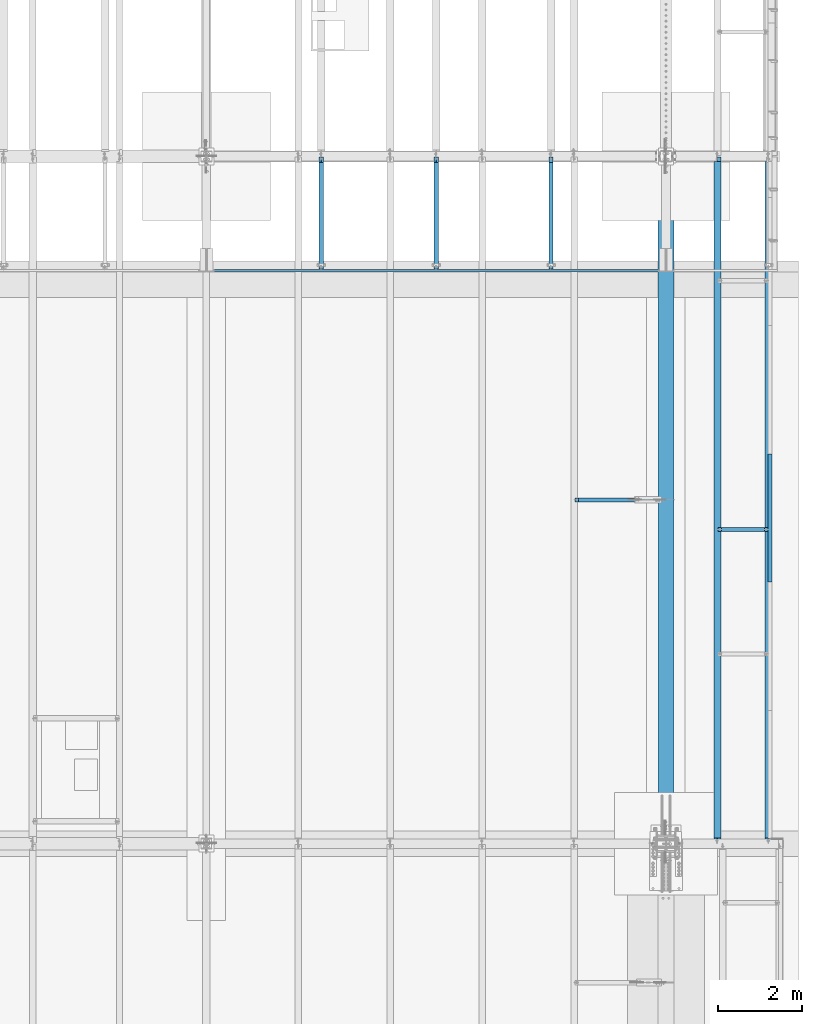
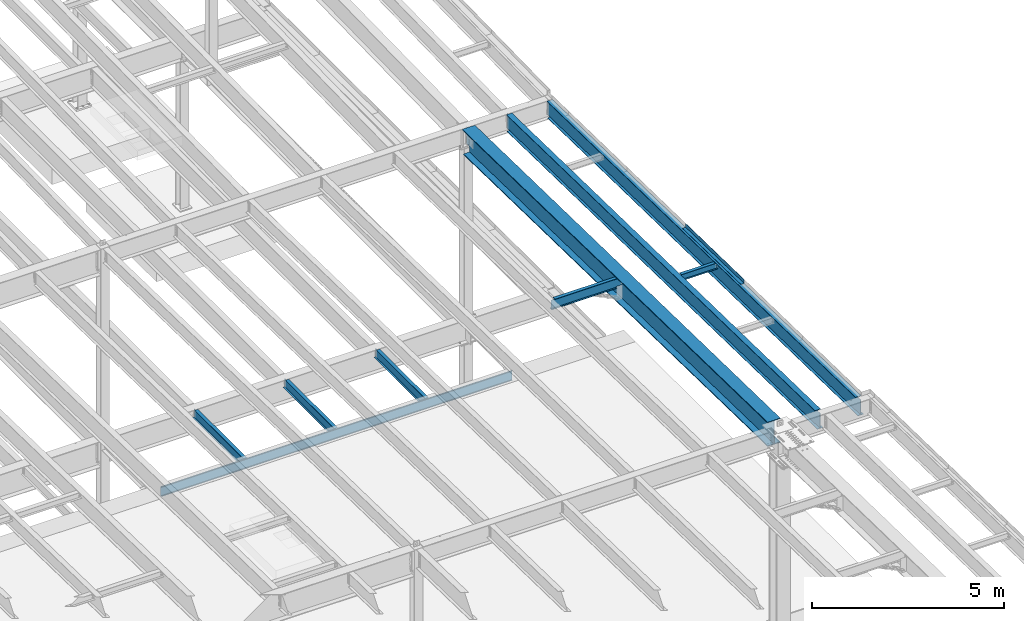
# One storey, part 1118 of 1763: 10 beams, 9 elements without a shape of their own.
"""IFC2X3 building model written with IfcOpenShell, lengths in millimetres."""

import ifcopenshell
import ifcopenshell.guid

model = None  # the IFC model being written
_history = None  # IfcOwnerHistory: only IFC2X3 demands one
_inside = {}  # id of a spatial element -> (the spatial element, [elements in it])
_under = {}  # id of a project, library or spatial element -> (it, [spatial elements below it])
_declared = {}  # id of a project -> (the project, [libraries it declares])
_typed = {}  # id of a type object -> (the type object, [elements of that type])
_made_of = {}  # id of a material, layer set ... -> (it, [elements and type objects made of it])


def new_model(schema):
    """Start an empty IFC model of exactly this schema.

    Asked for "IFC4X3", IfcOpenShell would pick the latest addendum, in which some entities
    have other attributes; the version numbers below select the first issue.
    IFC2X3 requires an IfcOwnerHistory on every rooted entity: one is made here for all.
    """
    global model, _history
    if schema == "IFC4X3":
        model = ifcopenshell.file(schema_version=(4, 3, 0, 0))
    else:
        model = ifcopenshell.file(schema=schema)
    _inside.clear()
    _under.clear()
    _declared.clear()
    _typed.clear()
    _made_of.clear()
    _history = None
    if model.schema == "IFC2X3":
        org = make("IfcOrganization", Name="unknown")
        user = make(
            "IfcPersonAndOrganization",
            ThePerson=make("IfcPerson", FamilyName="unknown"),
            TheOrganization=org,
        )
        app = make(
            "IfcApplication",
            ApplicationDeveloper=org,
            Version="unknown",
            ApplicationFullName="unknown",
            ApplicationIdentifier="unknown",
        )
        _history = make(
            "IfcOwnerHistory",
            OwningUser=user,
            OwningApplication=app,
            ChangeAction="ADDED",
            CreationDate=0,
        )
    return model


def make(cls, **values):
    """One entity of the class cls with the attributes given. An attribute that is None is left unset."""
    return model.create_entity(
        cls, **{name: value for name, value in values.items() if value is not None}
    )


def rooted(cls, **values):
    """An entity with a GlobalId (a new one), such as an element, a storey or a relation."""
    return make(cls, GlobalId=ifcopenshell.guid.new(), OwnerHistory=_history, **values)


def si_unit(unit_type, name, prefix=None):
    """IfcSIUnit, for example si_unit("LENGTHUNIT", "METRE", prefix="MILLI")."""
    return make("IfcSIUnit", UnitType=unit_type, Prefix=prefix, Name=name)


def assignment(units):
    """IfcUnitAssignment: the units of a project."""
    return None if units is None else make("IfcUnitAssignment", Units=units)


def point(xyz):
    """IfcCartesianPoint."""
    return None if xyz is None else make("IfcCartesianPoint", Coordinates=xyz)


def direction(xyz):
    """IfcDirection."""
    return None if xyz is None else make("IfcDirection", DirectionRatios=xyz)


def frame(location, z_axis=None, x_axis=None):
    """IfcAxis2Placement3D, a coordinate frame: its origin and axes. An axis left out is left unset."""
    return make(
        "IfcAxis2Placement3D",
        Location=point(location),
        Axis=direction(z_axis),
        RefDirection=direction(x_axis),
    )


def origin_with_axes():
    """The frame at (0, 0, 0) with the z axis (0, 0, 1) and the x axis (1, 0, 0) written out."""
    return frame((0.0, 0.0, 0.0), z_axis=(0.0, 0.0, 1.0), x_axis=(1.0, 0.0, 0.0))


def place(relative_to, where):
    """IfcLocalPlacement: puts the frame where relative to a parent placement (None: the world)."""
    return make(
        "IfcLocalPlacement", PlacementRelTo=relative_to, RelativePlacement=where
    )


def context(
    kind, dimensions, precision=None, world=None, true_north=None, identifier=None
):
    """IfcGeometricRepresentationContext, for example the 3D "Model" context."""
    return make(
        "IfcGeometricRepresentationContext",
        ContextIdentifier=identifier,
        ContextType=kind,
        CoordinateSpaceDimension=dimensions,
        Precision=precision,
        WorldCoordinateSystem=world,
        TrueNorth=true_north,
    )


def subcontext(parent, identifier, kind, view, scale=None):
    """IfcGeometricRepresentationSubContext, for example "Body" below "Model"."""
    return make(
        "IfcGeometricRepresentationSubContext",
        ContextIdentifier=identifier,
        ContextType=kind,
        ParentContext=parent,
        TargetScale=scale,
        TargetView=view,
    )


def project(units=None, contexts=None):
    """IfcProject with its units and contexts."""
    return rooted(
        "IfcProject",
        Name="project",
        RepresentationContexts=contexts,
        UnitsInContext=assignment(units),
    )


def spatial(cls, under=None, at=None, **own):
    """A site, building, storey or space (cls), placed at a placement, below another one or the project."""
    s = rooted(cls, ObjectPlacement=at, **own)
    if under is not None:
        _under.setdefault(under.id(), (under, []))[1].append(s)
    return s


def faces_of(points, faces, orient=None, outer=None):
    """IfcFace entities. A face is a list of loops; a loop is a list of indices into points, from 0.

    orient and outer hold one flag for each loop. By default every Orientation is true, the
    first loop of a face is its IfcFaceOuterBound and the others are IfcFaceBound.
    """
    made = []
    for i, loops in enumerate(faces):
        bounds = []
        for j, loop in enumerate(loops):
            is_outer = j == 0 if outer is None else outer[i][j]
            bounds.append(
                make(
                    "IfcFaceOuterBound" if is_outer else "IfcFaceBound",
                    Bound=make("IfcPolyLoop", Polygon=[points[k] for k in loop]),
                    Orientation=True if orient is None else orient[i][j],
                )
            )
        made.append(make("IfcFace", Bounds=bounds))
    return made


def faceted_brep(points, faces, orient=None, outer=None, voids=None):
    """IfcFacetedBrep: a solid bounded by flat faces; with voids (closed shells), ...WithVoids."""
    shared = [point(p) for p in points]
    hull = make("IfcClosedShell", CfsFaces=faces_of(shared, faces, orient, outer))
    if voids is None:
        return make("IfcFacetedBrep", Outer=hull)
    return make(
        "IfcFacetedBrepWithVoids",
        Outer=hull,
        Voids=[
            make(cls, CfsFaces=faces_of(shared, fs, o, b)) for cls, fs, o, b in voids
        ],
    )


def shape(context_of_items, identifier, shape_type, items):
    """IfcShapeRepresentation: the items that make up one representation, for example the "Body"."""
    return make(
        "IfcShapeRepresentation",
        ContextOfItems=context_of_items,
        RepresentationIdentifier=identifier,
        RepresentationType=shape_type,
        Items=items,
    )


def material(Name=None, Category=None):
    """IfcMaterial."""
    return make("IfcMaterial", Name=Name, Category=Category)


def made_of(thing, what):
    """Note that an element or type object is made of a material, layer set ...; save() writes the relation."""
    if what is not None:
        _made_of.setdefault(what.id(), (what, []))[1].append(thing)
    return thing


def type_object(cls, material=None, **own):
    """A type object (cls), such as IfcWallType, which elements share."""
    return made_of(rooted(cls, **own), material)


def element(
    cls,
    number,
    at=None,
    inside=None,
    cuts=None,
    type_object=None,
    material=None,
    context=None,
    identifier="Body",
    shape_type=None,
    held_by="IfcProductDefinitionShape",
    body=None,
    shapes=None,
    **own,
):
    """One element of the class cls, such as IfcWall. Its Tag is "e" and its number.

    at: its placement. inside: the storey or other place that contains it. cuts: it is an
    opening in that element (IfcRelVoidsElement). A single representation is given by context,
    identifier, shape_type and body (its items); several are given by shapes. held_by: the class
    of the entity that holds the representations. save() writes the other relations.
    """
    e = rooted(cls, Tag="e%d" % number, ObjectPlacement=at, **own)
    if body is not None:
        shapes = [shape(context, identifier, shape_type, body)]
    if shapes is not None:
        e.Representation = make(held_by, Representations=shapes)
    if inside is not None:
        _inside.setdefault(inside.id(), (inside, []))[1].append(e)
    if cuts is not None:
        rooted(
            "IfcRelVoidsElement", RelatingBuildingElement=cuts, RelatedOpeningElement=e
        )
    if type_object is not None:
        _typed.setdefault(type_object.id(), (type_object, []))[1].append(e)
    return made_of(e, material)


def aggregate(whole, parts):
    """IfcRelAggregates: a whole, such as a stair, and the parts it consists of."""
    return rooted("IfcRelAggregates", RelatingObject=whole, RelatedObjects=parts)


def save(model, path):
    """Write the relations noted so far, then the file.

    IfcRelAggregates (storeys below a building ...), IfcRelContainedInSpatialStructure (elements
    in a storey), IfcRelDefinesByType, IfcRelAssociatesMaterial and IfcRelDeclares: one each for
    every whole, place, type object, material and project.
    """
    for whole, parts in _under.values():
        aggregate(whole, parts)
    for where, things in _inside.values():
        rooted(
            "IfcRelContainedInSpatialStructure",
            RelatedElements=things,
            RelatingStructure=where,
        )
    for kind, things in _typed.values():
        rooted("IfcRelDefinesByType", RelatedObjects=things, RelatingType=kind)
    for what, things in _made_of.values():
        rooted("IfcRelAssociatesMaterial", RelatedObjects=things, RelatingMaterial=what)
    for by, libraries in _declared.values():
        rooted("IfcRelDeclares", RelatingContext=by, RelatedDefinitions=libraries)
    model.write(path)


model = new_model("IFC2X3")

# Units and contexts
model_context = context("Model", 3, precision=1e-05, world=origin_with_axes())
body_context = subcontext(model_context, "Body", "Model", "MODEL_VIEW")
ifc_project = project(units=[si_unit("LENGTHUNIT", "METRE", prefix="MILLI"), si_unit("AREAUNIT", "SQUARE_METRE"), si_unit("VOLUMEUNIT", "CUBIC_METRE"), si_unit("MASSUNIT", "GRAM", prefix="KILO"), si_unit("TIMEUNIT", "SECOND"), si_unit("PLANEANGLEUNIT", "RADIAN"), si_unit("SOLIDANGLEUNIT", "STERADIAN"), si_unit("THERMODYNAMICTEMPERATUREUNIT", "DEGREE_CELSIUS"), si_unit("LUMINOUSINTENSITYUNIT", "LUMEN")], contexts=[model_context])

# Site, building, storey
site_placement = place(None, origin_with_axes())
site = spatial("IfcSite", under=ifc_project, at=site_placement, CompositionType="ELEMENT")
building_placement = place(site_placement, origin_with_axes())
building = spatial("IfcBuilding", under=site, at=building_placement, Name="Undefined", CompositionType="ELEMENT")
storey_placement = place(building_placement, origin_with_axes())
storey = spatial("IfcBuildingStorey", under=building, at=storey_placement, Name="Undefined", CompositionType="ELEMENT", Elevation=0.0)

# Assembly, beam
assembly_1_placement = place(storey_placement, origin_with_axes())
assembly_1 = element("IfcElementAssembly", 1, at=assembly_1_placement, inside=storey, Name="BEAM", AssemblyPlace="NOTDEFINED", PredefinedType="RIGID_FRAME")
ifc_material_1 = material(Name="STEEL/A36")
beam_type_1 = type_object("IfcBeamType", PredefinedType="NOTDEFINED")
beam_1_placement = place(assembly_1_placement, frame((-21608.4906443556, 21429.6375485228, 11473.1236920469), z_axis=(0.0, -0.999781542838788, 0.0209013539966307), x_axis=(1.0, 0.0, 0.0)))
beam_1 = element("IfcBeam", 2, at=beam_1_placement, type_object=beam_type_1, material=ifc_material_1, Name="BENT_PLATE", context=body_context, shape_type="Brep", body=[
    faceted_brep([(0.0, -3.17499999999927, -1523.99999999999), (0.0, -3.17499999999927, 1524.0), (0.0, 3.17499999999927, 1524.0), (0.0, 3.17499999999927, -1523.99999999999), (95.2499984741262, 3.17499999910251, 1523.99999999978), (95.2499984741262, 3.17500000090149, -1523.99999999977), (101.599998474125, -3.17499999909887, -1523.99999999978), (101.599999809252, -3.17500000000655, 1524.0), (95.2499984741262, 123.825003587437, 1523.99999999985), (95.2499984741262, 123.825003589236, -1523.9999999997), (101.599998474125, 123.825003587437, 1523.99999999985), (101.599998474125, 123.825003589236, -1523.9999999997)], [[[0, 1, 2, 3]], [[3, 2, 4, 5]], [[1, 0, 6, 7]], [[5, 4, 8, 9]], [[4, 2, 1, 7, 10, 8]], [[7, 6, 11, 10]], [[6, 0, 3, 5, 9, 11]], [[10, 11, 9, 8]]]),
])

assembly_2_placement = place(storey_placement, origin_with_axes())
assembly_2 = element("IfcElementAssembly", 3, at=assembly_2_placement, inside=storey, Name="BEAM", AssemblyPlace="NOTDEFINED", PredefinedType="RIGID_FRAME")
ifc_material_2 = material(Name="STEEL/A992")
beam_type_2 = type_object("IfcBeamType", Name="W8X10", PredefinedType="NOTDEFINED")
beam_2_placement = place(assembly_2_placement, frame((-22808.6484080275, 21153.1204163198, 11375.7163444523), z_axis=(0.0, 0.0, 1.0), x_axis=(1.0, 0.0, 0.0)))
beam_2 = element("IfcBeam", 4, at=beam_2_placement, type_object=beam_type_2, material=ifc_material_2, Name="BEAM", ObjectType="W8X10", context=body_context, shape_type="Brep", body=[
    faceted_brep([(1119.19526367187, -50.7999999999993, 100.012500000001), (1119.19526367187, -50.7999999999993, 95.25), (1119.19526367187, -2.38124999999854, 95.25), (1119.19526367187, -2.38124999999854, 83.877501483119), (1119.19526367187, 2.38124999999854, 83.877501483119), (1119.19526367187, 2.38124999999854, 95.25), (1119.19526367187, 50.7999999999993, 95.25), (1119.19526367187, 50.7999999999993, 100.012500000001), (1120.16199359446, -2.38124999999854, 79.0174219650726), (1120.16199359446, 2.38124999999854, 79.0174219650726), (1122.91500749494, -2.38124999999854, 74.8972454969189), (1122.91500749494, 2.38124999999854, 74.8972454969189), (1127.03518396309, -2.38124999999854, 72.1442315964414), (1127.03518396309, 2.38124999999854, 72.1442315964414), (1131.89526348114, -2.38124999999854, 71.1775016738538), (1131.89526348114, 2.38124999999854, 71.1775016738538), (1201.74526367187, -2.38124999999854, 71.1775016738538), (1201.74526367187, 2.38124999999854, 71.1775016738538), (100.012500000012, -50.7999999999993, 100.012500000001), (100.012500000012, 50.7999999999993, 100.012500000001), (100.012500000012, 50.7999999999993, 95.25), (100.012500000012, 2.38124999999854, 95.25), (100.012500000012, 2.38124999999854, 83.877501483119), (100.012500000012, -2.38124999999854, 83.877501483119), (100.012500000012, -2.38124999999854, 95.25), (100.012500000012, -50.7999999999993, 95.25), (99.0457700774241, 2.38124999999854, 79.0174219650726), (99.0457700774241, -2.38124999999854, 79.0174219650726), (96.2927561769466, 2.38124999999854, 74.8972454969189), (96.2927561769466, -2.38124999999854, 74.8972454969189), (92.1725797087929, 2.38124999999854, 72.1442315964414), (92.1725797087929, -2.38124999999854, 72.1442315964414), (87.3125001907465, 2.38124999999854, 71.1775016738538), (87.3125001907465, -2.38124999999854, 71.1775016738538), (17.4625000000015, 2.38124999999854, 71.1775016738538), (17.4625000000015, -2.38124999999854, 71.1775016738538), (17.462499935149, 2.38124999999854, -95.25), (17.4625000000015, 50.7999999999993, -95.25), (17.4625000000015, 50.7999999999993, -100.012500000001), (17.4624996160601, -50.8000000000029, -100.012500000001), (17.4624996160601, -50.8000000000029, -95.25), (17.4624999065727, -2.38124999999854, -95.25), (1201.74526367187, 2.38124999999854, -95.25), (1201.74526367187, 50.7999999999993, -95.25), (1201.74526367187, 50.7999999999993, -100.012500000001), (1201.74526367187, -50.7999999999993, -100.012500000001), (1201.74526367187, -50.7999999999993, -95.25), (1201.74526367187, -2.38124999999854, -95.25)], [[[0, 1, 2, 3, 4, 5, 6, 7]], [[8, 9, 4, 3]], [[10, 11, 9, 8]], [[12, 13, 11, 10]], [[14, 15, 13, 12]], [[16, 17, 15, 14]], [[18, 19, 20, 21, 22, 23, 24, 25]], [[23, 22, 26, 27]], [[27, 26, 28, 29]], [[29, 28, 30, 31]], [[31, 30, 32, 33]], [[33, 32, 34, 35]], [[36, 37, 38, 39, 40, 41, 35, 34]], [[37, 36, 42, 43]], [[38, 37, 43, 44]], [[39, 38, 44, 45]], [[40, 39, 45, 46]], [[41, 40, 46, 47]], [[12, 10, 8, 3, 2, 24, 23, 27, 29, 31, 33, 35, 41, 47, 16, 14]], [[25, 24, 2, 1]], [[18, 25, 1, 0]], [[19, 18, 0, 7]], [[20, 19, 7, 6]], [[21, 20, 6, 5]], [[42, 36, 34, 32, 30, 28, 26, 22, 21, 5, 4, 9, 11, 13, 15, 17]], [[47, 46, 45, 44, 43, 42, 17, 16]]]),
])
aggregate(assembly_2, [beam_2])

assembly_3_placement = place(storey_placement, origin_with_axes())
assembly_3 = element("IfcElementAssembly", 5, at=assembly_3_placement, inside=storey, Name="BEAM", AssemblyPlace="NOTDEFINED", PredefinedType="RIGID_FRAME")
beam_type_3 = type_object("IfcBeamType", Name="W12X16", PredefinedType="NOTDEFINED")
beam_3_placement = place(assembly_3_placement, frame((-26758.3372736984, 27279.6, 5041.9), z_axis=(0.0, 0.0, 1.0), x_axis=(0.0, 1.0, 0.0)))
beam_3 = element("IfcBeam", 6, at=beam_3_placement, type_object=beam_type_3, material=ifc_material_2, Name="BEAM", ObjectType="W12X16", context=body_context, shape_type="Brep", body=[
    faceted_brep([(63.5000000000036, -3.17499999999927, -146.05), (63.5000000000036, -50.7999999999993, -146.05), (2724.15000000001, -50.7999999999993, -146.05), (2724.15000000001, -3.17499999999927, -146.05), (63.5000000000036, -50.7999999999993, -152.4), (2724.15000000001, -50.7999999999993, -152.4), (63.5000000000036, 50.7999999999993, -152.4), (2724.15000000001, 50.7999999999993, -152.4), (63.5000000000036, 50.7999999999993, -146.05), (63.5000000000036, 3.17499999999927, -146.05), (2724.15000000001, 3.17499999999927, -146.05), (2724.15000000001, 50.7999999999993, -146.05), (2724.15000000001, 3.17499999999927, 120.390001678466), (2724.15000000001, -3.17499999999927, 120.390001678466), (63.5000000000036, -3.17499999999927, 146.05), (63.5000000000036, -50.7999999999993, 146.05), (63.5000000000036, -50.7999999999993, 152.4), (63.5000000000036, 50.7999999999993, 152.4), (63.5000000000036, 50.7999999999993, 146.05), (63.5000000000036, 3.17499999999927, 146.05), (2597.15000000001, 50.7999999999993, 146.05), (2597.15000000001, 3.17499999999927, 146.05), (2597.15000000001, 3.17499999999927, 133.090001487731), (2598.11672992259, 3.17499999999927, 128.229921969685), (2600.86974382307, 3.17499999999927, 124.109745501532), (2604.98992029122, 3.17499999999927, 121.356731601053), (2609.84999980927, 3.17499999999927, 120.390001678466), (2598.11672992259, -3.17499999999927, 128.229921969685), (2597.15000000001, -3.17499999999927, 133.090001487731), (2600.86974382307, -3.17499999999927, 124.109745501532), (2604.98992029122, -3.17499999999927, 121.356731601053), (2609.84999980927, -3.17499999999927, 120.390001678466), (2597.15000000001, -3.17499999999927, 146.05), (2597.15000000001, -50.7999999999993, 146.05), (2597.15000000001, -50.7999999999993, 152.4), (2597.15000000001, 50.7999999999993, 152.4)], [[[0, 1, 2, 3]], [[1, 4, 5, 2]], [[4, 6, 7, 5]], [[8, 9, 10, 11]], [[3, 2, 5, 7, 11, 10, 12, 13]], [[6, 8, 11, 7]], [[4, 1, 0, 14, 15, 16, 17, 18, 19, 9, 8, 6]], [[19, 18, 20, 21]], [[10, 9, 19, 21, 22, 23, 24, 25, 26, 12]], [[27, 23, 22, 28]], [[29, 24, 23, 27]], [[30, 25, 24, 29]], [[31, 26, 25, 30]], [[13, 12, 26, 31]], [[30, 29, 27, 28, 32, 14, 0, 3, 13, 31]], [[15, 14, 32, 33]], [[16, 15, 33, 34]], [[17, 16, 34, 35]], [[18, 17, 35, 20]], [[34, 33, 32, 28, 22, 21, 20, 35]]]),
])
aggregate(assembly_3, [beam_3])

assembly_4_placement = place(storey_placement, origin_with_axes())
assembly_4 = element("IfcElementAssembly", 7, at=assembly_4_placement, inside=storey, Name="BEAM", AssemblyPlace="NOTDEFINED", PredefinedType="RIGID_FRAME")
beam_4_placement = place(assembly_4_placement, frame((-32219.3372736984, 27279.6, 5041.9), z_axis=(0.0, 0.0, 1.0), x_axis=(0.0, 1.0, 0.0)))
beam_4 = element("IfcBeam", 8, at=beam_4_placement, type_object=beam_type_3, material=ifc_material_2, Name="BEAM", ObjectType="W12X16", context=body_context, shape_type="Brep", body=[
    faceted_brep([(63.5000000000036, -3.17499999999927, -146.05), (63.5000000000036, -50.7999999999993, -146.05), (2724.15000000001, -50.7999999999993, -146.05), (2724.15000000001, -3.17499999999927, -146.05), (63.5000000000036, -50.7999999999993, -152.4), (2724.15000000001, -50.7999999999993, -152.4), (63.5000000000036, 50.7999999999993, -152.4), (2724.15000000001, 50.7999999999993, -152.4), (63.5000000000036, 50.7999999999993, -146.05), (63.5000000000036, 3.17499999999927, -146.05), (2724.15000000001, 3.17499999999927, -146.05), (2724.15000000001, 50.7999999999993, -146.05), (2724.15000000001, 3.17499999999927, 120.390001678466), (2724.15000000001, -3.17499999999927, 120.390001678466), (63.5000000000036, -3.17499999999927, 146.05), (63.5000000000036, -50.7999999999993, 146.05), (63.5000000000036, -50.7999999999993, 152.4), (63.5000000000036, 50.7999999999993, 152.4), (63.5000000000036, 50.7999999999993, 146.05), (63.5000000000036, 3.17499999999927, 146.05), (2597.15000000001, 50.7999999999993, 146.05), (2597.15000000001, 3.17499999999927, 146.05), (2597.15000000001, 3.17499999999927, 133.090001487731), (2598.11672992259, 3.17499999999927, 128.229921969685), (2600.86974382307, 3.17499999999927, 124.109745501532), (2604.98992029122, 3.17499999999927, 121.356731601053), (2609.84999980927, 3.17499999999927, 120.390001678466), (2598.11672992259, -3.17499999999927, 128.229921969685), (2597.15000000001, -3.17499999999927, 133.090001487731), (2600.86974382307, -3.17499999999927, 124.109745501532), (2604.98992029122, -3.17499999999927, 121.356731601053), (2609.84999980927, -3.17499999999927, 120.390001678466), (2597.15000000001, -3.17499999999927, 146.05), (2597.15000000001, -50.7999999999993, 146.05), (2597.15000000001, -50.7999999999993, 152.4), (2597.15000000001, 50.7999999999993, 152.4)], [[[0, 1, 2, 3]], [[1, 4, 5, 2]], [[4, 6, 7, 5]], [[8, 9, 10, 11]], [[3, 2, 5, 7, 11, 10, 12, 13]], [[6, 8, 11, 7]], [[4, 1, 0, 14, 15, 16, 17, 18, 19, 9, 8, 6]], [[19, 18, 20, 21]], [[10, 9, 19, 21, 22, 23, 24, 25, 26, 12]], [[27, 23, 22, 28]], [[29, 24, 23, 27]], [[30, 25, 24, 29]], [[31, 26, 25, 30]], [[13, 12, 26, 31]], [[30, 29, 27, 28, 32, 14, 0, 3, 13, 31]], [[15, 14, 32, 33]], [[16, 15, 33, 34]], [[17, 16, 34, 35]], [[18, 17, 35, 20]], [[34, 33, 32, 28, 22, 21, 20, 35]]]),
])
aggregate(assembly_4, [beam_4])

assembly_5_placement = place(storey_placement, origin_with_axes())
assembly_5 = element("IfcElementAssembly", 9, at=assembly_5_placement, inside=storey, Name="BEAM", AssemblyPlace="NOTDEFINED", PredefinedType="RIGID_FRAME")
beam_5_placement = place(assembly_5_placement, frame((-29488.8372736984, 27279.6, 5041.9), z_axis=(0.0, 0.0, 1.0), x_axis=(0.0, 1.0, 0.0)))
beam_5 = element("IfcBeam", 10, at=beam_5_placement, type_object=beam_type_3, material=ifc_material_2, Name="BEAM", ObjectType="W12X16", context=body_context, shape_type="Brep", body=[
    faceted_brep([(63.5000000000036, -3.17499999999927, -146.05), (63.5000000000036, -50.7999999999993, -146.05), (2724.15000000001, -50.7999999999993, -146.05), (2724.15000000001, -3.17499999999927, -146.05), (63.5000000000036, -50.7999999999993, -152.4), (2724.15000000001, -50.7999999999993, -152.4), (63.5000000000036, 50.7999999999993, -152.4), (2724.15000000001, 50.7999999999993, -152.4), (63.5000000000036, 50.7999999999993, -146.05), (63.5000000000036, 3.17499999999927, -146.05), (2724.15000000001, 3.17499999999927, -146.05), (2724.15000000001, 50.7999999999993, -146.05), (2724.15000000001, 3.17499999999927, 120.390001678466), (2724.15000000001, -3.17499999999927, 120.390001678466), (63.5000000000036, -3.17499999999927, 146.05), (63.5000000000036, -50.7999999999993, 146.05), (63.5000000000036, -50.7999999999993, 152.4), (63.5000000000036, 50.7999999999993, 152.4), (63.5000000000036, 50.7999999999993, 146.05), (63.5000000000036, 3.17499999999927, 146.05), (2597.15000000001, 50.7999999999993, 146.05), (2597.15000000001, 3.17499999999927, 146.05), (2597.15000000001, 3.17499999999927, 133.090001487731), (2598.11672992259, 3.17499999999927, 128.229921969685), (2600.86974382307, 3.17499999999927, 124.109745501532), (2604.98992029122, 3.17499999999927, 121.356731601053), (2609.84999980927, 3.17499999999927, 120.390001678466), (2598.11672992259, -3.17499999999927, 128.229921969685), (2597.15000000001, -3.17499999999927, 133.090001487731), (2600.86974382307, -3.17499999999927, 124.109745501532), (2604.98992029122, -3.17499999999927, 121.356731601053), (2609.84999980927, -3.17499999999927, 120.390001678466), (2597.15000000001, -3.17499999999927, 146.05), (2597.15000000001, -50.7999999999993, 146.05), (2597.15000000001, -50.7999999999993, 152.4), (2597.15000000001, 50.7999999999993, 152.4)], [[[0, 1, 2, 3]], [[1, 4, 5, 2]], [[4, 6, 7, 5]], [[8, 9, 10, 11]], [[3, 2, 5, 7, 11, 10, 12, 13]], [[6, 8, 11, 7]], [[4, 1, 0, 14, 15, 16, 17, 18, 19, 9, 8, 6]], [[19, 18, 20, 21]], [[10, 9, 19, 21, 22, 23, 24, 25, 26, 12]], [[27, 23, 22, 28]], [[29, 24, 23, 27]], [[30, 25, 24, 29]], [[31, 26, 25, 30]], [[13, 12, 26, 31]], [[30, 29, 27, 28, 32, 14, 0, 3, 13, 31]], [[15, 14, 32, 33]], [[16, 15, 33, 34]], [[17, 16, 34, 35]], [[18, 17, 35, 20]], [[34, 33, 32, 28, 22, 21, 20, 35]]]),
])
aggregate(assembly_5, [beam_5])

assembly_6_placement = place(storey_placement, origin_with_axes())
assembly_6 = element("IfcElementAssembly", 11, at=assembly_6_placement, inside=storey, Name="BEAM", AssemblyPlace="NOTDEFINED", PredefinedType="RIGID_FRAME")
beam_type_4 = type_object("IfcBeamType", Name="W12X22", PredefinedType="NOTDEFINED")
beam_6_placement = place(assembly_6_placement, frame((-26212.2372736983, 21856.7000000305, 11305.4448631154), z_axis=(0.0, 0.0, 1.0), x_axis=(1.0, 0.0, 0.0)))
beam_6 = element("IfcBeam", 12, at=beam_6_placement, type_object=beam_type_4, material=ifc_material_2, Name="BEAM", ObjectType="W12X22", context=body_context, shape_type="Brep", body=[
    faceted_brep([(1973.26249999999, -3.17499999999927, -144.4625), (1973.26249999999, -50.7999999999993, -144.4625), (1973.26249999999, -50.7999999999993, -155.575000000001), (1973.26249999999, 50.7999999999993, -155.575000000001), (1973.26249999999, 50.7999999999993, -144.4625), (1973.26249999999, 3.17499999999927, -144.4625), (1973.26249999999, 3.17499999999927, -136.524999809046), (1973.26249999999, -3.17499999999927, -136.524999809046), (1974.22922992258, 3.17499999999927, -131.664920290999), (1974.22922992258, -3.17499999999927, -131.664920290999), (1976.98224382305, 3.17499999999927, -127.544743822846), (1976.98224382305, -3.17499999999927, -127.544743822846), (1981.10242029121, 3.17499999999927, -124.791729922368), (1981.10242029121, -3.17499999999927, -124.791729922368), (1985.96249980925, 3.17499999999927, -123.824999999781), (1985.96249980925, -3.17499999999927, -123.824999999781), (2163.76249999999, -3.17499999999927, -123.824999999781), (2163.76249999999, 3.17499999999927, -123.824999999781), (105.568749999995, 3.17499999999927, 144.4625), (105.568749999995, 50.7999999999993, 144.4625), (1973.26249999999, 50.7999999999993, 144.4625), (1973.26249999999, 3.17499999999927, 144.4625), (16.6687499999898, 3.17499999999927, -144.4625), (16.6687499999898, 50.7999999999993, -144.4625), (16.6687499999898, 50.7999999999993, -155.575000000001), (16.6687499999898, -50.7999999999993, -155.575000000001), (16.6687499999898, -50.7999999999993, -144.4625), (16.6687499999898, -3.17499999999927, -144.4625), (16.6687499999898, -3.17499999999927, 123.565001683279), (16.6687499999898, 3.17499999999927, 123.565001683279), (92.8687501907298, -3.17499999999927, 123.565001683279), (92.8687501907298, 3.17499999999927, 123.565001683279), (97.7288297087762, -3.17499999999927, 124.531731605866), (97.7288297087762, 3.17499999999927, 124.531731605866), (101.84900617693, -3.17499999999927, 127.284745506344), (101.84900617693, 3.17499999999927, 127.284745506344), (104.602020077407, -3.17499999999927, 131.404921974497), (104.602020077407, 3.17499999999927, 131.404921974497), (105.568749999995, -3.17499999999927, 136.265001492544), (105.568749999995, 3.17499999999927, 136.265001492544), (105.568749999995, -50.7999999999993, 155.575000000001), (105.568749999995, 50.7999999999993, 155.575000000001), (105.568749999995, -3.17499999999927, 144.4625), (105.568749999995, -50.7999999999993, 144.4625), (1973.26249999999, -3.17499999999927, 144.4625), (1973.26249999999, -50.7999999999993, 144.4625), (1973.26249999999, -50.7999999999993, 155.575000000001), (1973.26249999999, 50.7999999999993, 155.575000000001), (1973.26249999999, -3.17499999999927, 123.824999809485), (1973.26249999999, 3.17499999999927, 123.824999809485), (1974.22922992258, -3.17499999999927, 118.964920291439), (1974.22922992258, 3.17499999999927, 118.964920291439), (1976.98224382305, -3.17499999999927, 114.844743823285), (1976.98224382305, 3.17499999999927, 114.844743823285), (1981.10242029121, -3.17499999999927, 112.091729922808), (1981.10242029121, 3.17499999999927, 112.091729922808), (1985.96249980925, -3.17499999999927, 111.12500000022), (1985.96249980925, 3.17499999999927, 111.12500000022), (2163.76249999999, -3.17499999999927, 111.12500000022), (2163.76249999999, 3.17499999999927, 111.12500000022)], [[[0, 1, 2, 3, 4, 5, 6, 7]], [[7, 6, 8, 9]], [[9, 8, 10, 11]], [[11, 10, 12, 13]], [[13, 12, 14, 15]], [[16, 15, 14, 17]], [[18, 19, 20, 21]], [[22, 23, 24, 25, 26, 27, 28, 29]], [[30, 31, 29, 28]], [[32, 33, 31, 30]], [[34, 35, 33, 32]], [[36, 37, 35, 34]], [[38, 39, 37, 36]], [[40, 41, 19, 18, 39, 38, 42, 43]], [[43, 42, 44, 45]], [[40, 43, 45, 46]], [[41, 40, 46, 47]], [[19, 41, 47, 20]], [[46, 45, 44, 48, 49, 21, 20, 47]], [[50, 51, 49, 48]], [[52, 53, 51, 50]], [[54, 55, 53, 52]], [[56, 57, 55, 54]], [[58, 59, 57, 56]], [[59, 58, 16, 17]], [[12, 10, 8, 6, 5, 22, 29, 31, 33, 35, 37, 39, 18, 21, 49, 51, 53, 55, 57, 59, 17, 14]], [[23, 22, 5, 4]], [[24, 23, 4, 3]], [[25, 24, 3, 2]], [[26, 25, 2, 1]], [[27, 26, 1, 0]], [[58, 56, 54, 52, 50, 48, 44, 42, 38, 36, 34, 32, 30, 28, 27, 0, 7, 9, 11, 13, 15, 16]]]),
])
aggregate(assembly_6, [beam_6])

assembly_7_placement = place(storey_placement, origin_with_axes())
assembly_7 = element("IfcElementAssembly", 13, at=assembly_7_placement, inside=storey, Name="BEAM", AssemblyPlace="NOTDEFINED", PredefinedType="RIGID_FRAME")
beam_type_5 = type_object("IfcBeamType", Name="MC12X10.6", PredefinedType="NOTDEFINED")
beam_7_placement = place(assembly_7_placement, frame((-34767.2747736984, 27311.35, 5041.9), z_axis=(0.0, 0.0, 1.0), x_axis=(1.0, 0.0, 0.0)))
beam_7 = element("IfcBeam", 14, at=beam_7_placement, type_object=beam_type_5, material=ifc_material_2, Name="BEAM", ObjectType="MC12X10.6", context=body_context, shape_type="Brep", body=[
    faceted_brep([(0.0, 19.0499999999993, -152.4), (0.0, 19.0499999999993, 152.4), (10556.875, 19.0499999999993, 152.4), (10556.875, 19.0499999999993, -152.4), (0.0, -19.0499999999993, 152.4), (10556.875, -19.0499999999993, 152.4), (0.0, -19.0499999999993, 144.841595), (10556.875, -19.0499999999993, 144.841595), (0.0, 14.2874999999985, 144.17817875), (10556.875, 14.2874999999985, 144.17817875), (0.0, 14.2874999999985, -144.17817875), (10556.875, 14.2874999999985, -144.17817875), (0.0, -19.0499999999993, -144.841595), (10556.875, -19.0499999999993, -144.841595), (0.0, -19.0499999999993, -152.4), (10556.875, -19.0499999999993, -152.4)], [[[0, 1, 2, 3]], [[1, 4, 5, 2]], [[4, 6, 7, 5]], [[6, 8, 9, 7]], [[8, 10, 11, 9]], [[10, 12, 13, 11]], [[12, 14, 15, 13]], [[14, 0, 3, 15]], [[5, 7, 9, 11, 13, 15, 3, 2]], [[14, 12, 10, 8, 6, 4, 1, 0]]]),
])
aggregate(assembly_7, [beam_7])

assembly_8_placement = place(storey_placement, origin_with_axes())
assembly_8 = element("IfcElementAssembly", 15, at=assembly_8_placement, inside=storey, Name="BEAM", AssemblyPlace="NOTDEFINED", PredefinedType="RIGID_FRAME")
beam_type_6 = type_object("IfcBeamType", Name="W30X173", PredefinedType="NOTDEFINED")
beam_8_placement = place(assembly_8_placement, frame((-24027.8372736984, 13682.5038593573, 11244.4743488694), z_axis=(0.0, 0.0209013539966291, 0.999781542838788), x_axis=(0.0, 0.999781542776098, -0.0209013569953182)))
beam_8 = element("IfcBeam", 16, at=beam_8_placement, type_object=beam_type_6, material=ifc_material_2, Name="BEAM", ObjectType="W30X173", context=body_context, shape_type="Brep", body=[
    faceted_brep([(16318.4376960657, -7.9375, 342.900000057462), (16318.4376960657, 7.9375, 342.900000057462), (16235.8696584814, 7.9375, 342.900000057414), (16219.4042468993, 7.9375, 342.900000057403), (16219.4042468993, -7.9375, 342.900000057403), (16214.5441673812, 7.9375, 343.866729979987), (16214.5441673812, -7.9375, 343.866729979987), (16210.4239909131, 7.9375, 346.619743880461), (16210.4239909131, -7.9375, 346.619743880461), (16207.6709770126, 7.9375, 350.739920348613), (16207.6709770126, -7.9375, 350.739920348613), (16206.70424709, 7.9375, 355.599999866654), (16206.70424709, -7.9375, 355.599999866654), (303.842952070128, -190.5, 360.362500000125), (303.842952070128, -7.9375, 360.362500000125), (16206.70424709, -7.9375, 360.362500009489), (16206.70424709, -190.5, 360.362500009489), (303.278753444951, -190.5, 387.350000000122), (16206.70424709, -190.5, 387.350000009485), (303.278753444951, 190.5, 387.350000000122), (16206.70424709, 190.5, 387.350000009485), (303.842952070128, 190.5, 360.362500000125), (16206.70424709, 190.5, 360.362500009489), (16206.70424709, 7.9375, 360.362500009489), (303.842952070128, 7.9375, 360.362500000125), (319.474572802957, -190.5, -387.349999999755), (318.910374177782, -190.5, -360.362499999761), (318.910374177782, -7.9375, -360.362499999761), (318.910374177782, 7.9375, -360.362499999761), (318.910374177782, 190.5, -360.362499999761), (319.474572802957, 190.5, -387.349999999755), (16168.6042470901, 7.9375, -360.362499990428), (16168.6042470901, 190.5, -360.362499990428), (16168.6042470901, 190.5, -387.349999990423), (16168.6042470901, -190.5, -387.349999990423), (16168.6042470901, -190.5, -360.362499990428), (16168.6042470901, -7.9375, -360.362499990428), (16168.60424709, -7.9375, -196.849999751628), (16169.5709770126, -7.9375, -191.989920233584), (16172.3239909131, -7.9375, -187.869743765432), (16176.4441673812, -7.9375, -185.116729864951), (16181.3042468993, -7.9375, -184.149999942361), (16329.4561633338, -7.9375, -184.149999942254), (16329.4561633338, 7.9375, -184.149999942254), (16181.3042468993, 7.9375, -184.149999942361), (16176.4441673812, 7.9375, -185.116729864951), (16172.3239909131, 7.9375, -187.869743765432), (16169.5709770126, 7.9375, -191.989920233584), (16168.60424709, 7.9375, -196.849999751628), (16246.8881257496, 7.9375, -184.149999942312)], [[[0, 1, 2, 3, 4]], [[4, 3, 5, 6]], [[6, 5, 7, 8]], [[8, 7, 9, 10]], [[10, 9, 11, 12]], [[13, 14, 15, 16]], [[17, 13, 16, 18]], [[19, 17, 18, 20]], [[21, 19, 20, 22]], [[18, 16, 15, 12, 11, 23, 22, 20]], [[24, 21, 22, 23]], [[25, 26, 27, 14, 13, 17, 19, 21, 24, 28, 29, 30]], [[29, 28, 31, 32]], [[30, 29, 32, 33]], [[25, 30, 33, 34]], [[26, 25, 34, 35]], [[27, 26, 35, 36]], [[0, 4, 6, 8, 10, 12, 15, 14, 27, 36, 37, 38, 39, 40, 41, 42]], [[1, 0, 42, 43]], [[44, 45, 46, 47, 48, 31, 28, 24, 23, 11, 9, 7, 5, 3, 2, 1, 43, 49]], [[42, 41, 44, 49, 43]], [[40, 45, 44, 41]], [[39, 46, 45, 40]], [[38, 47, 46, 39]], [[37, 48, 47, 38]], [[36, 35, 34, 33, 32, 31, 48, 37]]]),
])
aggregate(assembly_8, [beam_8])

# Beam
beam_type_7 = type_object("IfcBeamType", Name="W21X44", PredefinedType="NOTDEFINED")
beam_9_placement = place(assembly_1_placement, frame((-21589.4406443556, 13685.125150802, 11369.8594516026), z_axis=(0.0, 0.0209013539966291, 0.999781542838788), x_axis=(0.0, 0.999781542776098, -0.0209013569953182)))
beam_9 = element("IfcBeam", 17, at=beam_9_placement, type_object=beam_type_7, material=ifc_material_2, Name="BEAM", ObjectType="W21X44", context=body_context, shape_type="Brep", body=[
    faceted_brep([(16195.9844677689, 5.06257982341049, -250.824999990424), (16195.984467769, 5.06241404162211, -261.937499990423), (16195.9844631971, 82.5499999999993, -261.937499990423), (16195.9844631971, 82.5499999999993, -250.824999990424), (16328.2282016106, 5.06258762587822, -250.824999990346), (16328.4605186916, 5.06242185780502, -261.937499990345), (138.036284288731, 4.76250000000073, 250.825000000154), (138.036284288731, 82.5499999999993, 250.825000000154), (16208.6844732034, 82.5499999999993, 250.825000009509), (16208.6844732034, 4.76250000000073, 250.825000009509), (138.03628428873, -82.5499999999993, 261.937500000162), (138.03628428873, 82.5499999999993, 261.937500000162), (138.036284288756, 4.76250000000073, 236.277501488014), (138.036284288756, -4.76250000000073, 236.277501488014), (138.036284288731, -4.76250000000073, 250.825000000154), (138.036284288731, -82.5499999999993, 250.825000000154), (137.069554366171, 4.76250000000073, 231.417421969954), (137.069554366171, -4.76250000000073, 231.417421969954), (134.316540465695, 4.76250000000073, 227.297245501792), (134.316540465695, -4.76250000000073, 227.297245501792), (130.196363997542, 4.76250000000073, 224.544231601307), (130.196363997542, -4.76250000000073, 224.544231601307), (125.336284479495, 4.76250000000073, 223.577501678723), (125.336284479495, -4.76250000000073, 223.577501678723), (19.0621902439588, 4.76250000000073, 223.577501678721), (19.0621902439588, -4.76250000000073, 223.577501678721), (28.9800124366774, 4.76250000000073, -250.825000000208), (28.9800124366774, 82.5499999999993, -250.825000000208), (29.2123295065213, 82.5499999999993, -261.937500000218), (29.2123295065213, -82.5499999999993, -261.937500000218), (28.9800124366774, -82.5499999999993, -250.825000000208), (28.9800124366774, -4.76250000000073, -250.825000000208), (16328.4605186916, -82.5499999999993, -261.937499990345), (16328.2282016106, -82.5499999999993, -250.824999990346), (16328.2282016106, -4.76250000000073, -250.824999990346), (16216.5243934946, -4.76250000000073, 224.544231745098), (16212.4042170265, -4.76250000000073, 227.297245645574), (16209.651203126, -4.76250000000073, 231.417422113724), (16208.6844732034, -4.76250000000073, 236.277501631766), (16208.6844732034, -4.76250000000073, 250.825000009509), (16318.3103789408, -4.76250000000073, 223.57750182257), (16221.3844730127, -4.76250000000073, 223.577501822514), (16208.6844732034, -82.5499999999993, 250.825000009509), (16208.6844732034, -82.5499999999993, 261.937500009508), (16208.6844732034, 82.5499999999993, 261.937500009508), (16208.6844732034, 4.76250000000073, 236.277501631766), (16209.651203126, 4.76250000000073, 231.417422113724), (16212.4042170265, 4.76250000000073, 227.297245645574), (16216.5243934946, 4.76250000000073, 224.544231745098), (16221.3844730127, 4.76250000000073, 223.577501822514), (16318.3103789408, 4.76250000000073, 223.57750182257), (16328.2282016106, 4.76250000000073, -250.824999990346)], [[[0, 1, 2, 3]], [[4, 5, 1, 0]], [[6, 7, 8, 9]], [[10, 11, 7, 6, 12, 13, 14, 15]], [[13, 12, 16, 17]], [[17, 16, 18, 19]], [[19, 18, 20, 21]], [[21, 20, 22, 23]], [[23, 22, 24, 25]], [[26, 27, 28, 29, 30, 31, 25, 24]], [[30, 29, 32, 33]], [[31, 30, 33, 34]], [[35, 36, 37, 38, 39, 14, 13, 17, 19, 21, 23, 25, 31, 34, 40, 41]], [[15, 14, 39, 42]], [[10, 15, 42, 43]], [[11, 10, 43, 44]], [[7, 11, 44, 8]], [[43, 42, 39, 38, 45, 9, 8, 44]], [[37, 46, 45, 38]], [[36, 47, 46, 37]], [[35, 48, 47, 36]], [[41, 49, 48, 35]], [[40, 50, 49, 41]], [[51, 26, 24, 22, 20, 18, 16, 12, 6, 9, 45, 46, 47, 48, 49, 50]], [[3, 27, 26, 51, 4, 0]], [[28, 27, 3, 2]], [[32, 29, 28, 2, 1, 5]], [[51, 50, 40, 34, 33, 32, 5, 4]]]),
])

aggregate(assembly_1, [beam_1, beam_9])

# Assembly, beam
assembly_9_placement = place(storey_placement, origin_with_axes())
assembly_9 = element("IfcElementAssembly", 18, at=assembly_9_placement, inside=storey, Name="BEAM", AssemblyPlace="NOTDEFINED", PredefinedType="RIGID_FRAME")
beam_10_placement = place(assembly_9_placement, frame((-22808.6484080275, 13685.125150802, 11369.8594516026), z_axis=(0.0, 0.0209013539966291, 0.999781542838788), x_axis=(0.0, 0.999781542776098, -0.0209013569953182)))
beam_10 = element("IfcBeam", 19, at=beam_10_placement, type_object=beam_type_7, material=ifc_material_2, Name="BEAM", ObjectType="W21X44", context=body_context, shape_type="Brep", body=[
    faceted_brep([(16195.9844677689, 5.06257982341049, -250.824999990424), (16195.984467769, 5.06241404162211, -261.937499990423), (16195.9844631971, 82.5499999999993, -261.937499990423), (16195.9844631971, 82.5499999999993, -250.824999990424), (16328.2282016106, 5.06258762587822, -250.824999990346), (16328.4605186916, 5.06242185780502, -261.937499990345), (138.036284288731, 4.76250000000073, 250.825000000154), (138.036284288731, 82.5499999999993, 250.825000000154), (16208.6844732034, 82.5499999999993, 250.825000009509), (16208.6844732034, 4.76250000000073, 250.825000009509), (138.03628428873, -82.5499999999993, 261.937500000162), (138.03628428873, 82.5499999999993, 261.937500000162), (138.036284288756, 4.76250000000073, 236.277501488014), (138.036284288756, -4.76250000000073, 236.277501488014), (138.036284288731, -4.76250000000073, 250.825000000154), (138.036284288731, -82.5499999999993, 250.825000000154), (137.069554366171, 4.76250000000073, 231.417421969954), (137.069554366171, -4.76250000000073, 231.417421969954), (134.316540465695, 4.76250000000073, 227.297245501792), (134.316540465695, -4.76250000000073, 227.297245501792), (130.196363997542, 4.76250000000073, 224.544231601307), (130.196363997542, -4.76250000000073, 224.544231601307), (125.336284479495, 4.76250000000073, 223.577501678723), (125.336284479495, -4.76250000000073, 223.577501678723), (19.0621902439588, 4.76250000000073, 223.577501678721), (19.0621902439588, -4.76250000000073, 223.577501678721), (28.9800124366774, 4.76250000000073, -250.825000000208), (28.9800124366774, 82.5499999999993, -250.825000000208), (29.2123295065213, 82.5499999999993, -261.937500000218), (29.2123295065213, -82.5499999999993, -261.937500000218), (28.9800124366774, -82.5499999999993, -250.825000000208), (28.9800124366774, -4.76250000000073, -250.825000000208), (16328.4605186916, -82.5499999999993, -261.937499990345), (16328.2282016106, -82.5499999999993, -250.824999990346), (16328.2282016106, -4.76250000000073, -250.824999990346), (16216.5243934946, -4.76250000000073, 224.544231745098), (16212.4042170265, -4.76250000000073, 227.297245645574), (16209.651203126, -4.76250000000073, 231.417422113724), (16208.6844732034, -4.76250000000073, 236.277501631766), (16208.6844732034, -4.76250000000073, 250.825000009509), (16318.3103789408, -4.76250000000073, 223.57750182257), (16221.3844730127, -4.76250000000073, 223.577501822514), (16208.6844732034, -82.5499999999993, 250.825000009509), (16208.6844732034, -82.5499999999993, 261.937500009508), (16208.6844732034, 82.5499999999993, 261.937500009508), (16208.6844732034, 4.76250000000073, 236.277501631766), (16209.651203126, 4.76250000000073, 231.417422113724), (16212.4042170265, 4.76250000000073, 227.297245645574), (16216.5243934946, 4.76250000000073, 224.544231745098), (16221.3844730127, 4.76250000000073, 223.577501822514), (16318.3103789408, 4.76250000000073, 223.57750182257), (16328.2282016106, 4.76250000000073, -250.824999990346)], [[[0, 1, 2, 3]], [[4, 5, 1, 0]], [[6, 7, 8, 9]], [[10, 11, 7, 6, 12, 13, 14, 15]], [[13, 12, 16, 17]], [[17, 16, 18, 19]], [[19, 18, 20, 21]], [[21, 20, 22, 23]], [[23, 22, 24, 25]], [[26, 27, 28, 29, 30, 31, 25, 24]], [[30, 29, 32, 33]], [[31, 30, 33, 34]], [[35, 36, 37, 38, 39, 14, 13, 17, 19, 21, 23, 25, 31, 34, 40, 41]], [[15, 14, 39, 42]], [[10, 15, 42, 43]], [[11, 10, 43, 44]], [[7, 11, 44, 8]], [[43, 42, 39, 38, 45, 9, 8, 44]], [[37, 46, 45, 38]], [[36, 47, 46, 37]], [[35, 48, 47, 36]], [[41, 49, 48, 35]], [[40, 50, 49, 41]], [[51, 26, 24, 22, 20, 18, 16, 12, 6, 9, 45, 46, 47, 48, 49, 50]], [[3, 27, 26, 51, 4, 0]], [[28, 27, 3, 2]], [[32, 29, 28, 2, 1, 5]], [[51, 50, 40, 34, 33, 32, 5, 4]]]),
])
aggregate(assembly_9, [beam_10])

save(model, "model.ifc")
